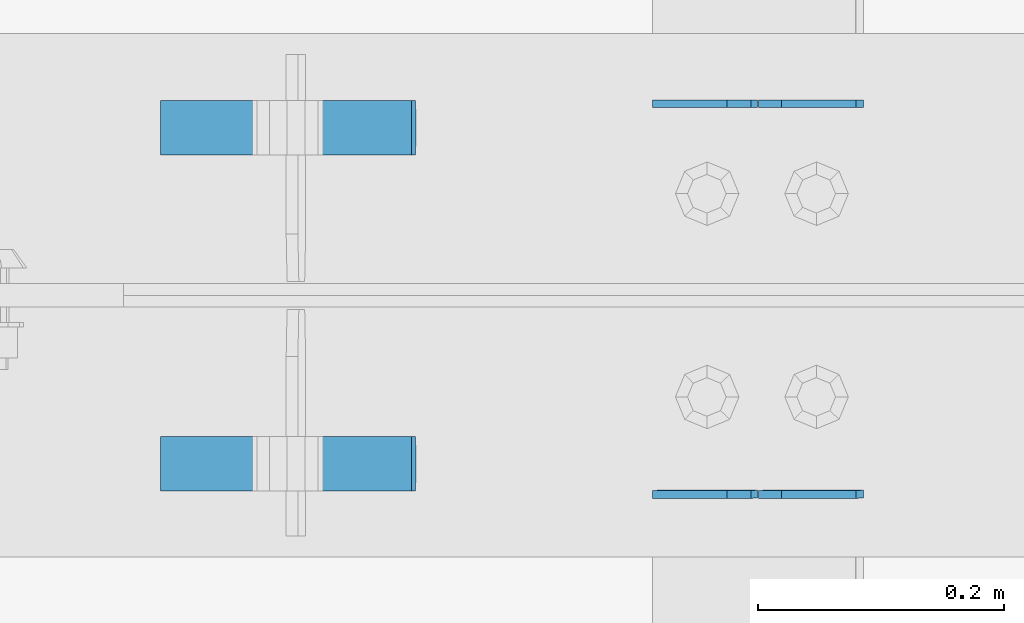
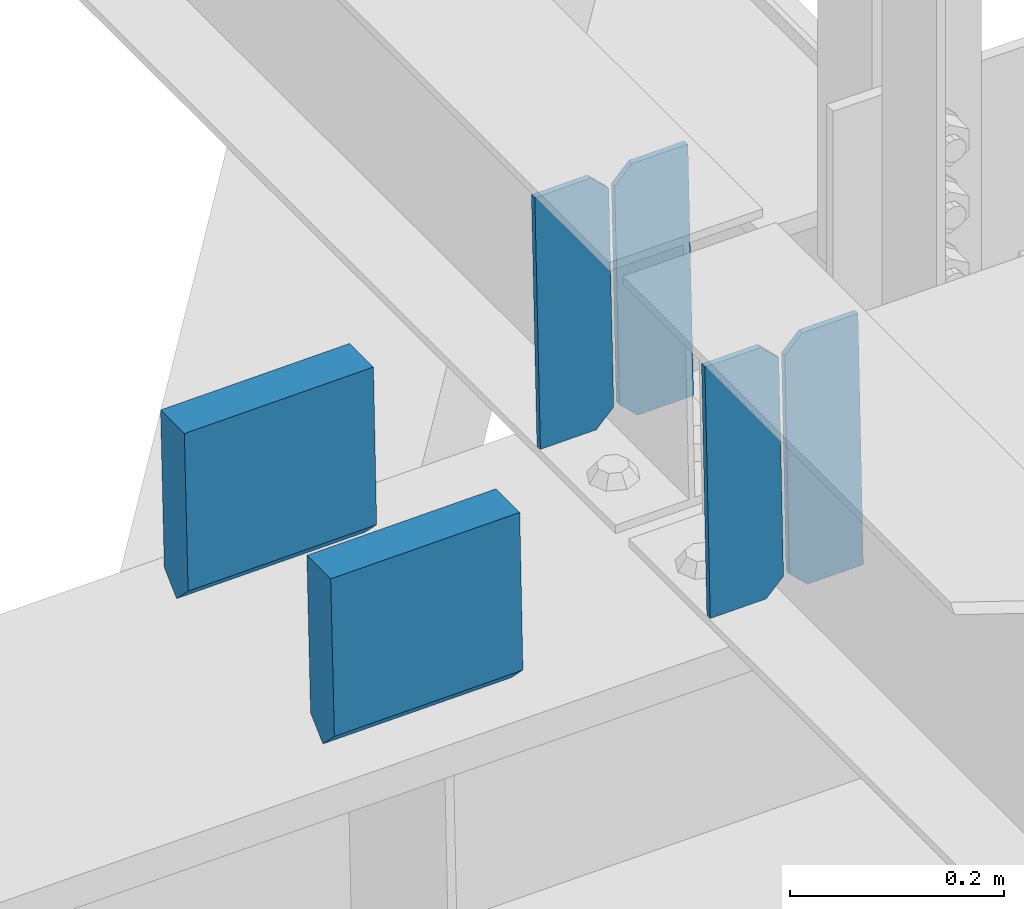
# One storey, part 3313 of 3843: 6 plates, 3 elements without a shape of their own.
"""IFC2X3 building model written with IfcOpenShell, lengths in millimetres."""

import ifcopenshell
import ifcopenshell.guid

model = None  # the IFC model being written
_history = None  # IfcOwnerHistory: only IFC2X3 demands one
_inside = {}  # id of a spatial element -> (the spatial element, [elements in it])
_under = {}  # id of a project, library or spatial element -> (it, [spatial elements below it])
_declared = {}  # id of a project -> (the project, [libraries it declares])
_typed = {}  # id of a type object -> (the type object, [elements of that type])
_made_of = {}  # id of a material, layer set ... -> (it, [elements and type objects made of it])


def new_model(schema):
    """Start an empty IFC model of exactly this schema.

    Asked for "IFC4X3", IfcOpenShell would pick the latest addendum, in which some entities
    have other attributes; the version numbers below select the first issue.
    IFC2X3 requires an IfcOwnerHistory on every rooted entity: one is made here for all.
    """
    global model, _history
    if schema == "IFC4X3":
        model = ifcopenshell.file(schema_version=(4, 3, 0, 0))
    else:
        model = ifcopenshell.file(schema=schema)
    _inside.clear()
    _under.clear()
    _declared.clear()
    _typed.clear()
    _made_of.clear()
    _history = None
    if model.schema == "IFC2X3":
        org = make("IfcOrganization", Name="unknown")
        user = make(
            "IfcPersonAndOrganization",
            ThePerson=make("IfcPerson", FamilyName="unknown"),
            TheOrganization=org,
        )
        app = make(
            "IfcApplication",
            ApplicationDeveloper=org,
            Version="unknown",
            ApplicationFullName="unknown",
            ApplicationIdentifier="unknown",
        )
        _history = make(
            "IfcOwnerHistory",
            OwningUser=user,
            OwningApplication=app,
            ChangeAction="ADDED",
            CreationDate=0,
        )
    return model


def make(cls, **values):
    """One entity of the class cls with the attributes given. An attribute that is None is left unset."""
    return model.create_entity(
        cls, **{name: value for name, value in values.items() if value is not None}
    )


def rooted(cls, **values):
    """An entity with a GlobalId (a new one), such as an element, a storey or a relation."""
    return make(cls, GlobalId=ifcopenshell.guid.new(), OwnerHistory=_history, **values)


def si_unit(unit_type, name, prefix=None):
    """IfcSIUnit, for example si_unit("LENGTHUNIT", "METRE", prefix="MILLI")."""
    return make("IfcSIUnit", UnitType=unit_type, Prefix=prefix, Name=name)


def assignment(units):
    """IfcUnitAssignment: the units of a project."""
    return None if units is None else make("IfcUnitAssignment", Units=units)


def point(xyz):
    """IfcCartesianPoint."""
    return None if xyz is None else make("IfcCartesianPoint", Coordinates=xyz)


def direction(xyz):
    """IfcDirection."""
    return None if xyz is None else make("IfcDirection", DirectionRatios=xyz)


def frame(location, z_axis=None, x_axis=None):
    """IfcAxis2Placement3D, a coordinate frame: its origin and axes. An axis left out is left unset."""
    return make(
        "IfcAxis2Placement3D",
        Location=point(location),
        Axis=direction(z_axis),
        RefDirection=direction(x_axis),
    )


def origin_with_axes():
    """The frame at (0, 0, 0) with the z axis (0, 0, 1) and the x axis (1, 0, 0) written out."""
    return frame((0.0, 0.0, 0.0), z_axis=(0.0, 0.0, 1.0), x_axis=(1.0, 0.0, 0.0))


def place(relative_to, where):
    """IfcLocalPlacement: puts the frame where relative to a parent placement (None: the world)."""
    return make(
        "IfcLocalPlacement", PlacementRelTo=relative_to, RelativePlacement=where
    )


def context(
    kind, dimensions, precision=None, world=None, true_north=None, identifier=None
):
    """IfcGeometricRepresentationContext, for example the 3D "Model" context."""
    return make(
        "IfcGeometricRepresentationContext",
        ContextIdentifier=identifier,
        ContextType=kind,
        CoordinateSpaceDimension=dimensions,
        Precision=precision,
        WorldCoordinateSystem=world,
        TrueNorth=true_north,
    )


def subcontext(parent, identifier, kind, view, scale=None):
    """IfcGeometricRepresentationSubContext, for example "Body" below "Model"."""
    return make(
        "IfcGeometricRepresentationSubContext",
        ContextIdentifier=identifier,
        ContextType=kind,
        ParentContext=parent,
        TargetScale=scale,
        TargetView=view,
    )


def project(units=None, contexts=None):
    """IfcProject with its units and contexts."""
    return rooted(
        "IfcProject",
        Name="project",
        RepresentationContexts=contexts,
        UnitsInContext=assignment(units),
    )


def spatial(cls, under=None, at=None, **own):
    """A site, building, storey or space (cls), placed at a placement, below another one or the project."""
    s = rooted(cls, ObjectPlacement=at, **own)
    if under is not None:
        _under.setdefault(under.id(), (under, []))[1].append(s)
    return s


def faces_of(points, faces, orient=None, outer=None):
    """IfcFace entities. A face is a list of loops; a loop is a list of indices into points, from 0.

    orient and outer hold one flag for each loop. By default every Orientation is true, the
    first loop of a face is its IfcFaceOuterBound and the others are IfcFaceBound.
    """
    made = []
    for i, loops in enumerate(faces):
        bounds = []
        for j, loop in enumerate(loops):
            is_outer = j == 0 if outer is None else outer[i][j]
            bounds.append(
                make(
                    "IfcFaceOuterBound" if is_outer else "IfcFaceBound",
                    Bound=make("IfcPolyLoop", Polygon=[points[k] for k in loop]),
                    Orientation=True if orient is None else orient[i][j],
                )
            )
        made.append(make("IfcFace", Bounds=bounds))
    return made


def faceted_brep(points, faces, orient=None, outer=None, voids=None):
    """IfcFacetedBrep: a solid bounded by flat faces; with voids (closed shells), ...WithVoids."""
    shared = [point(p) for p in points]
    hull = make("IfcClosedShell", CfsFaces=faces_of(shared, faces, orient, outer))
    if voids is None:
        return make("IfcFacetedBrep", Outer=hull)
    return make(
        "IfcFacetedBrepWithVoids",
        Outer=hull,
        Voids=[
            make(cls, CfsFaces=faces_of(shared, fs, o, b)) for cls, fs, o, b in voids
        ],
    )


def shape(context_of_items, identifier, shape_type, items):
    """IfcShapeRepresentation: the items that make up one representation, for example the "Body"."""
    return make(
        "IfcShapeRepresentation",
        ContextOfItems=context_of_items,
        RepresentationIdentifier=identifier,
        RepresentationType=shape_type,
        Items=items,
    )


def material(Name=None, Category=None):
    """IfcMaterial."""
    return make("IfcMaterial", Name=Name, Category=Category)


def made_of(thing, what):
    """Note that an element or type object is made of a material, layer set ...; save() writes the relation."""
    if what is not None:
        _made_of.setdefault(what.id(), (what, []))[1].append(thing)
    return thing


def type_object(cls, material=None, **own):
    """A type object (cls), such as IfcWallType, which elements share."""
    return made_of(rooted(cls, **own), material)


def element(
    cls,
    number,
    at=None,
    inside=None,
    cuts=None,
    type_object=None,
    material=None,
    context=None,
    identifier="Body",
    shape_type=None,
    held_by="IfcProductDefinitionShape",
    body=None,
    shapes=None,
    **own,
):
    """One element of the class cls, such as IfcWall. Its Tag is "e" and its number.

    at: its placement. inside: the storey or other place that contains it. cuts: it is an
    opening in that element (IfcRelVoidsElement). A single representation is given by context,
    identifier, shape_type and body (its items); several are given by shapes. held_by: the class
    of the entity that holds the representations. save() writes the other relations.
    """
    e = rooted(cls, Tag="e%d" % number, ObjectPlacement=at, **own)
    if body is not None:
        shapes = [shape(context, identifier, shape_type, body)]
    if shapes is not None:
        e.Representation = make(held_by, Representations=shapes)
    if inside is not None:
        _inside.setdefault(inside.id(), (inside, []))[1].append(e)
    if cuts is not None:
        rooted(
            "IfcRelVoidsElement", RelatingBuildingElement=cuts, RelatedOpeningElement=e
        )
    if type_object is not None:
        _typed.setdefault(type_object.id(), (type_object, []))[1].append(e)
    return made_of(e, material)


def aggregate(whole, parts):
    """IfcRelAggregates: a whole, such as a stair, and the parts it consists of."""
    return rooted("IfcRelAggregates", RelatingObject=whole, RelatedObjects=parts)


def save(model, path):
    """Write the relations noted so far, then the file.

    IfcRelAggregates (storeys below a building ...), IfcRelContainedInSpatialStructure (elements
    in a storey), IfcRelDefinesByType, IfcRelAssociatesMaterial and IfcRelDeclares: one each for
    every whole, place, type object, material and project.
    """
    for whole, parts in _under.values():
        aggregate(whole, parts)
    for where, things in _inside.values():
        rooted(
            "IfcRelContainedInSpatialStructure",
            RelatedElements=things,
            RelatingStructure=where,
        )
    for kind, things in _typed.values():
        rooted("IfcRelDefinesByType", RelatedObjects=things, RelatingType=kind)
    for what, things in _made_of.values():
        rooted("IfcRelAssociatesMaterial", RelatedObjects=things, RelatingMaterial=what)
    for by, libraries in _declared.values():
        rooted("IfcRelDeclares", RelatingContext=by, RelatedDefinitions=libraries)
    model.write(path)


model = new_model("IFC2X3")

# Units and contexts
model_context = context("Model", 3, precision=1e-05, world=origin_with_axes())
body_context = subcontext(model_context, "Body", "Model", "MODEL_VIEW")
ifc_project = project(units=[si_unit("LENGTHUNIT", "METRE", prefix="MILLI"), si_unit("AREAUNIT", "SQUARE_METRE"), si_unit("VOLUMEUNIT", "CUBIC_METRE"), si_unit("MASSUNIT", "GRAM", prefix="KILO"), si_unit("TIMEUNIT", "SECOND"), si_unit("PLANEANGLEUNIT", "RADIAN"), si_unit("SOLIDANGLEUNIT", "STERADIAN"), si_unit("THERMODYNAMICTEMPERATUREUNIT", "DEGREE_CELSIUS"), si_unit("LUMINOUSINTENSITYUNIT", "LUMEN")], contexts=[model_context])

# Site, building, storey
site_placement = place(None, origin_with_axes())
site = spatial("IfcSite", under=ifc_project, at=site_placement, CompositionType="ELEMENT")
building_placement = place(site_placement, origin_with_axes())
building = spatial("IfcBuilding", under=site, at=building_placement, Name="Undefined", CompositionType="ELEMENT")
storey_placement = place(building_placement, origin_with_axes())
storey = spatial("IfcBuildingStorey", under=building, at=storey_placement, Name="Undefined", CompositionType="ELEMENT", Elevation=0.0)

# Assembly, plates
assembly_1_placement = place(storey_placement, origin_with_axes())
assembly_1 = element("IfcElementAssembly", 1, at=assembly_1_placement, inside=storey, Name="BEAM", AssemblyPlace="NOTDEFINED", PredefinedType="RIGID_FRAME")
ifc_material = material(Name="STEEL/A572-50")
plate_type_1 = type_object("IfcPlateType", PredefinedType="NOTDEFINED")
plate_1_placement = place(assembly_1_placement, frame((72027.7964782846, 50714.4252424657, 46276.4675621838), z_axis=(-0.0211520976931496, -0.000503817000200796, 0.999776142409695), x_axis=(-0.999776269357268, 1.0337000006824e-05, -0.0211520950075907)))
plate_1 = element("IfcPlate", 2, at=plate_1_placement, type_object=plate_type_1, material=ifc_material, Name="PLATE", context=body_context, shape_type="Brep", body=[
    faceted_brep([(0.0, -3.17499999999927, 0.0), (6.83940015733242e-10, -3.17499999996653, 288.924999998613), (6.54836185276508e-10, 3.17500000001746, 288.924999998591), (0.0, 3.17499999999927, 0.0), (60.3250007643655, -3.17500000017753, 288.924999998606), (60.3250007643219, 3.17499999979918, 288.924999998584), (79.3750000013097, -3.17500000025029, 269.875000761494), (79.375000001266, 3.17499999972642, 269.875000761487), (79.375000000713, -3.17500000026484, 19.0499992370605), (79.3750000006985, 3.17499999971187, 19.0499992370533), (60.325000763667, -3.17500000020664, -1.45519152283669e-11), (60.3250007636234, 3.17499999977736, -3.63797880709171e-11)], [[[0, 1, 2, 3]], [[1, 4, 5, 2]], [[4, 6, 7, 5]], [[6, 8, 9, 7]], [[8, 10, 11, 9]], [[10, 0, 3, 11]], [[5, 7, 9, 11, 3, 2]], [[10, 8, 6, 4, 1, 0]]]),
])
plate_2_placement = place(assembly_1_placement, frame((71942.0906575934, 50714.4261562227, 46274.654298812), z_axis=(-0.0211520976931496, -0.000503817000200796, 0.999776142409695), x_axis=(-0.999776269357268, 1.0337000006824e-05, -0.0211520950075907)))
plate_2 = element("IfcPlate", 3, at=plate_2_placement, type_object=plate_type_1, material=ifc_material, Name="PLATE", context=body_context, shape_type="Brep", body=[
    faceted_brep([(4.36557456851006e-11, -3.17499999998836, 19.0499992370969), (6.11180439591408e-10, -3.17499999996653, 269.875000761516), (5.96628524363041e-10, 3.17500000001746, 269.875000761502), (1.45519152283669e-11, 3.17499999998836, 19.0499992370824), (19.0499992376572, -3.17500000003201, 288.924999998606), (19.0499992376281, 3.1749999999447, 288.924999998584), (79.3750000013242, -3.17500000025029, 288.924999998591), (79.3750000013097, 3.1749999997337, 288.92499999857), (79.3750000006548, -3.17500000026484, -2.18278728425503e-11), (79.3750000006403, 3.17499999969732, -2.91038304567337e-11), (19.0499992370023, -3.17500000005384, 0.0), (19.0499992369587, 3.17499999992287, -1.45519152283669e-11)], [[[0, 1, 2, 3]], [[1, 4, 5, 2]], [[4, 6, 7, 5]], [[6, 8, 9, 7]], [[8, 10, 11, 9]], [[10, 0, 3, 11]], [[5, 7, 9, 11, 3, 2]], [[10, 8, 6, 4, 1, 0]]]),
])
aggregate(assembly_1, [plate_1, plate_2])

assembly_2_placement = place(storey_placement, origin_with_axes())
assembly_2 = element("IfcElementAssembly", 4, at=assembly_2_placement, inside=storey, Name="BEAM", AssemblyPlace="NOTDEFINED", PredefinedType="RIGID_FRAME")
plate_3_placement = place(assembly_2_placement, frame((72027.7964782884, 50397.4101943243, 46276.0459685508), z_axis=(-0.0211520978771441, -0.00212704099933762, 0.999774006689503), x_axis=(-0.999776269348977, 4.5491000049241e-05, -0.0211520490073722)))
plate_3 = element("IfcPlate", 5, at=plate_3_placement, type_object=plate_type_1, material=ifc_material, Name="PLATE", context=body_context, shape_type="Brep", body=[
    faceted_brep([(0.0, -3.17499999999927, 0.0), (6.83940015733242e-10, -3.17499999996653, 288.924999998613), (6.54836185276508e-10, 3.17500000001746, 288.924999998591), (0.0, 3.17499999999927, 0.0), (60.3250007643655, -3.17500000017753, 288.924999998606), (60.3250007643219, 3.17499999979918, 288.924999998584), (79.3750000013097, -3.17500000025029, 269.875000761494), (79.375000001266, 3.17499999972642, 269.875000761487), (79.375000000713, -3.17500000026484, 19.0499992370605), (79.3750000006985, 3.17499999971187, 19.0499992370533), (60.325000763667, -3.17500000020664, -1.45519152283669e-11), (60.3250007636234, 3.17499999977736, -3.63797880709171e-11)], [[[0, 1, 2, 3]], [[1, 4, 5, 2]], [[4, 6, 7, 5]], [[6, 8, 9, 7]], [[8, 10, 11, 9]], [[10, 0, 3, 11]], [[5, 7, 9, 11, 3, 2]], [[10, 8, 6, 4, 1, 0]]]),
])
plate_4_placement = place(assembly_2_placement, frame((71942.0906575972, 50397.4140520735, 46274.2327090535), z_axis=(-0.0211520978771441, -0.00212704099933762, 0.999774006689503), x_axis=(-0.999776269348977, 4.5491000049241e-05, -0.0211520490073722)))
plate_4 = element("IfcPlate", 6, at=plate_4_placement, type_object=plate_type_1, material=ifc_material, Name="PLATE", context=body_context, shape_type="Brep", body=[
    faceted_brep([(4.36557456851006e-11, -3.17499999998836, 19.0499992370969), (6.11180439591408e-10, -3.17499999996653, 269.875000761516), (5.96628524363041e-10, 3.17500000001746, 269.875000761502), (1.45519152283669e-11, 3.17499999998836, 19.0499992370824), (19.0499992376572, -3.17500000003201, 288.924999998606), (19.0499992376281, 3.1749999999447, 288.924999998584), (79.3750000013242, -3.17500000025029, 288.924999998591), (79.3750000013097, 3.1749999997337, 288.92499999857), (79.3750000006548, -3.17500000026484, -2.18278728425503e-11), (79.3750000006403, 3.17499999969732, -2.91038304567337e-11), (19.0499992370023, -3.17500000005384, 0.0), (19.0499992369587, 3.17499999992287, -1.45519152283669e-11)], [[[0, 1, 2, 3]], [[1, 4, 5, 2]], [[4, 6, 7, 5]], [[6, 8, 9, 7]], [[8, 10, 11, 9]], [[10, 0, 3, 11]], [[5, 7, 9, 11, 3, 2]], [[10, 8, 6, 4, 1, 0]]]),
])
aggregate(assembly_2, [plate_3, plate_4])

assembly_3_placement = place(storey_placement, origin_with_axes())
assembly_3 = element("IfcElementAssembly", 7, at=assembly_3_placement, inside=storey, Name="BEAM", AssemblyPlace="NOTDEFINED", PredefinedType="RIGID_FRAME")
plate_type_2 = type_object("IfcPlateType", PredefinedType="NOTDEFINED")
plate_5_placement = place(assembly_3_placement, frame((71456.7376992281, 50694.828125, 46456.5710147164), z_axis=(0.0217666070074993, 0.0, -0.999763079343992), x_axis=(0.999763079343992, 0.0, 0.0217666070075027)))
plate_5 = element("IfcPlate", 8, at=plate_5_placement, type_object=plate_type_2, material=ifc_material, Name="PLATE", context=body_context, shape_type="Brep", body=[
    faceted_brep([(203.200005058941, -22.2250000000058, -1.16415321826935e-10), (7.27595761418343e-12, -22.2250000000058, -7.27595761418343e-12), (7.27595761418343e-12, 22.2250000000058, -7.27595761418343e-12), (203.200005058941, 22.2250000000058, -1.16415321826935e-10), (203.838531807472, -22.2250000000058, 0.00187068080413155), (203.838531807472, 22.2250000000058, 0.00187068080413155), (203.310341304641, -22.2250000000058, 180.861817383484), (0.04046799018397, -22.2250000000058, 180.907287948779), (203.245434494536, 0.0133131837355904, 203.086833080139), (0.0454396034692763, 0.0133129994646879, 203.132287829787), (0.0404679902494536, 22.2250000000058, 180.907288225317), (203.310341303353, 22.2250000000058, 180.861817822159)], [[[0, 1, 2, 3]], [[4, 0, 3, 5]], [[1, 0, 4, 6, 7]], [[7, 6, 8, 9]], [[2, 1, 7, 9, 10]], [[5, 3, 2, 10, 11]], [[6, 4, 5, 11, 8]], [[10, 9, 8, 11]]]),
])
plate_6_placement = place(assembly_3_placement, frame((71456.7376992281, 50421.778125, 46456.5710147164), z_axis=(0.0217666070074993, 0.0, -0.999763079343992), x_axis=(0.999763079343992, 0.0, 0.0217666070075027)))
plate_6 = element("IfcPlate", 9, at=plate_6_placement, type_object=plate_type_2, material=ifc_material, Name="PLATE", context=body_context, shape_type="Brep", body=[
    faceted_brep([(203.200005058941, -22.2250000000058, -1.16415321826935e-10), (7.27595761418343e-12, -22.2250000000058, -7.27595761418343e-12), (7.27595761418343e-12, 22.2250000000058, -7.27595761418343e-12), (203.200005058941, 22.2250000000058, -1.16415321826935e-10), (203.838531807472, -22.2250000000058, 0.00187068080413155), (203.838531807472, 22.2250000000058, 0.00187068080413155), (203.310341304641, -22.2250000000058, 180.861817383484), (0.04046799018397, -22.2250000000058, 180.907287948779), (203.245434494536, 0.0133131837355904, 203.086833080139), (0.0454396034692763, 0.0133129994646879, 203.132287829787), (0.0404679902494536, 22.2250000000058, 180.907288225317), (203.310341303353, 22.2250000000058, 180.861817822159)], [[[0, 1, 2, 3]], [[4, 0, 3, 5]], [[1, 0, 4, 6, 7]], [[7, 6, 8, 9]], [[2, 1, 7, 9, 10]], [[5, 3, 2, 10, 11]], [[6, 4, 5, 11, 8]], [[10, 9, 8, 11]]]),
])
aggregate(assembly_3, [plate_5, plate_6])

save(model, "model.ifc")
